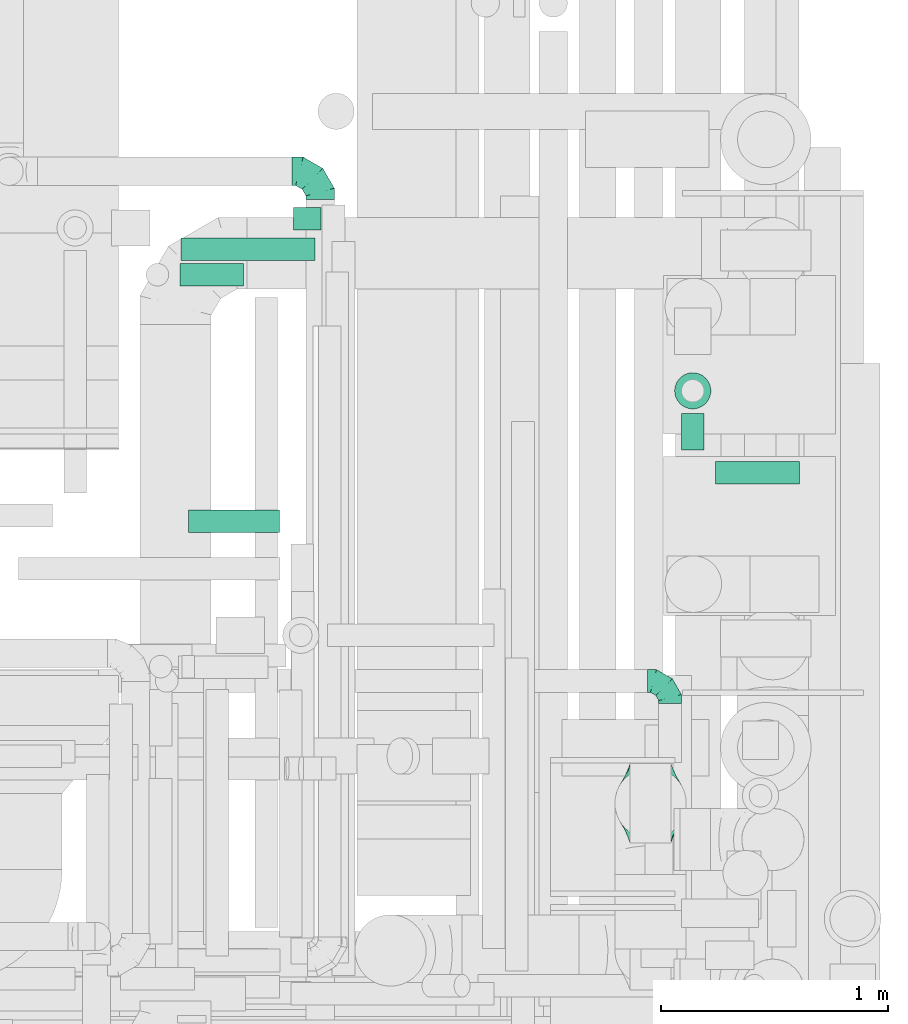
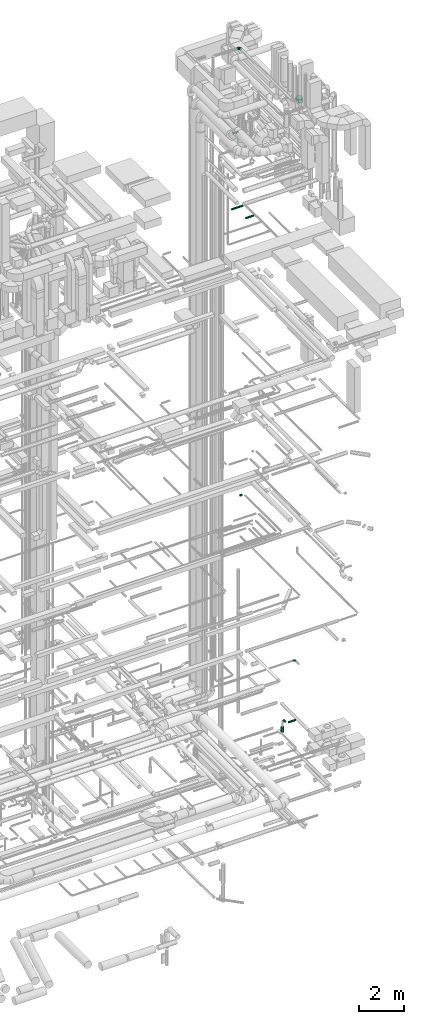
# One storey, part 309 of 337: 7 flow segments, 3 flow fittings.
"""IFC2X3 building model written with IfcOpenShell, lengths in millimetres."""

import ifcopenshell
import ifcopenshell.guid

model = None  # the IFC model being written
_history = None  # IfcOwnerHistory: only IFC2X3 demands one
_inside = {}  # id of a spatial element -> (the spatial element, [elements in it])
_under = {}  # id of a project, library or spatial element -> (it, [spatial elements below it])
_declared = {}  # id of a project -> (the project, [libraries it declares])
_typed = {}  # id of a type object -> (the type object, [elements of that type])
_made_of = {}  # id of a material, layer set ... -> (it, [elements and type objects made of it])


def new_model(schema):
    """Start an empty IFC model of exactly this schema.

    Asked for "IFC4X3", IfcOpenShell would pick the latest addendum, in which some entities
    have other attributes; the version numbers below select the first issue.
    IFC2X3 requires an IfcOwnerHistory on every rooted entity: one is made here for all.
    """
    global model, _history
    if schema == "IFC4X3":
        model = ifcopenshell.file(schema_version=(4, 3, 0, 0))
    else:
        model = ifcopenshell.file(schema=schema)
    _inside.clear()
    _under.clear()
    _declared.clear()
    _typed.clear()
    _made_of.clear()
    _history = None
    if model.schema == "IFC2X3":
        org = make("IfcOrganization", Name="unknown")
        user = make(
            "IfcPersonAndOrganization",
            ThePerson=make("IfcPerson", FamilyName="unknown"),
            TheOrganization=org,
        )
        app = make(
            "IfcApplication",
            ApplicationDeveloper=org,
            Version="unknown",
            ApplicationFullName="unknown",
            ApplicationIdentifier="unknown",
        )
        _history = make(
            "IfcOwnerHistory",
            OwningUser=user,
            OwningApplication=app,
            ChangeAction="ADDED",
            CreationDate=0,
        )
    return model


def make(cls, **values):
    """One entity of the class cls with the attributes given. An attribute that is None is left unset."""
    return model.create_entity(
        cls, **{name: value for name, value in values.items() if value is not None}
    )


def entity(cls, *values):
    """Any entity or typed value of the class cls, its attributes in the order of the schema. None: left unset."""
    e = model.create_entity(cls)
    for i, value in enumerate(values):
        if value is not None:
            e[i] = value
    return e


def rooted(cls, **values):
    """An entity with a GlobalId (a new one), such as an element, a storey or a relation."""
    return make(cls, GlobalId=ifcopenshell.guid.new(), OwnerHistory=_history, **values)


def si_unit(unit_type, name, prefix=None):
    """IfcSIUnit, for example si_unit("LENGTHUNIT", "METRE", prefix="MILLI")."""
    return make("IfcSIUnit", UnitType=unit_type, Prefix=prefix, Name=name)


def converted_unit(unit_type, name, factor, base, dimensions=None, offset=None):
    """IfcConversionBasedUnit, such as the inch: factor (a typed value) times the base unit."""
    return make(
        "IfcConversionBasedUnit"
        if offset is None
        else "IfcConversionBasedUnitWithOffset",
        ConversionOffset=offset,
        Dimensions=None
        if dimensions is None
        else entity("IfcDimensionalExponents", *dimensions),
        UnitType=unit_type,
        Name=name,
        ConversionFactor=make(
            "IfcMeasureWithUnit", ValueComponent=factor, UnitComponent=base
        ),
    )


def derived_unit(unit_type, elements):
    """IfcDerivedUnit: a product of units, each with its exponent."""
    return make(
        "IfcDerivedUnit",
        Elements=[
            make("IfcDerivedUnitElement", Unit=unit, Exponent=power)
            for unit, power in elements
        ],
        UnitType=unit_type,
    )


def assignment(units):
    """IfcUnitAssignment: the units of a project."""
    return None if units is None else make("IfcUnitAssignment", Units=units)


def point(xyz):
    """IfcCartesianPoint."""
    return None if xyz is None else make("IfcCartesianPoint", Coordinates=xyz)


def direction(xyz):
    """IfcDirection."""
    return None if xyz is None else make("IfcDirection", DirectionRatios=xyz)


def frame(location, z_axis=None, x_axis=None):
    """IfcAxis2Placement3D, a coordinate frame: its origin and axes. An axis left out is left unset."""
    return make(
        "IfcAxis2Placement3D",
        Location=point(location),
        Axis=direction(z_axis),
        RefDirection=direction(x_axis),
    )


def frame_2d(location, x_axis=None):
    """IfcAxis2Placement2D, a coordinate frame in the plane: its origin and x axis."""
    return make(
        "IfcAxis2Placement2D", Location=point(location), RefDirection=direction(x_axis)
    )


def origin():
    """The frame at (0, 0, 0) with its axes left unset."""
    return frame((0.0, 0.0, 0.0))


def origin_2d_with_axis():
    """The frame at (0, 0) in the plane with the x axis (1, 0) written out."""
    return frame_2d((0.0, 0.0), x_axis=(1.0, 0.0))


def place(relative_to, where):
    """IfcLocalPlacement: puts the frame where relative to a parent placement (None: the world)."""
    return make(
        "IfcLocalPlacement", PlacementRelTo=relative_to, RelativePlacement=where
    )


def context(
    kind, dimensions, precision=None, world=None, true_north=None, identifier=None
):
    """IfcGeometricRepresentationContext, for example the 3D "Model" context."""
    return make(
        "IfcGeometricRepresentationContext",
        ContextIdentifier=identifier,
        ContextType=kind,
        CoordinateSpaceDimension=dimensions,
        Precision=precision,
        WorldCoordinateSystem=world,
        TrueNorth=true_north,
    )


def subcontext(parent, identifier, kind, view, scale=None):
    """IfcGeometricRepresentationSubContext, for example "Body" below "Model"."""
    return make(
        "IfcGeometricRepresentationSubContext",
        ContextIdentifier=identifier,
        ContextType=kind,
        ParentContext=parent,
        TargetScale=scale,
        TargetView=view,
    )


def project(units=None, contexts=None):
    """IfcProject with its units and contexts."""
    return rooted(
        "IfcProject",
        Name="project",
        RepresentationContexts=contexts,
        UnitsInContext=assignment(units),
    )


def spatial(cls, under=None, at=None, **own):
    """A site, building, storey or space (cls), placed at a placement, below another one or the project."""
    s = rooted(cls, ObjectPlacement=at, **own)
    if under is not None:
        _under.setdefault(under.id(), (under, []))[1].append(s)
    return s


def profile(cls, at=None, kind="AREA", **sizes):
    """A parametric profile (cls). Its sizes go by their IFC names, for example OverallWidth=200.0."""
    return make(cls, ProfileType=kind, Position=at, **sizes)


def circle(**sizes):
    """IfcCircleProfileDef."""
    return profile("IfcCircleProfileDef", **sizes)


def extrude(swept, where, along, depth):
    """IfcExtrudedAreaSolid: the profile swept, set in the frame where, extruded along a direction by depth."""
    return make(
        "IfcExtrudedAreaSolid",
        SweptArea=swept,
        Position=where,
        ExtrudedDirection=direction(along),
        Depth=depth,
    )


def faces_of(points, faces, orient=None, outer=None):
    """IfcFace entities. A face is a list of loops; a loop is a list of indices into points, from 0.

    orient and outer hold one flag for each loop. By default every Orientation is true, the
    first loop of a face is its IfcFaceOuterBound and the others are IfcFaceBound.
    """
    made = []
    for i, loops in enumerate(faces):
        bounds = []
        for j, loop in enumerate(loops):
            is_outer = j == 0 if outer is None else outer[i][j]
            bounds.append(
                make(
                    "IfcFaceOuterBound" if is_outer else "IfcFaceBound",
                    Bound=make("IfcPolyLoop", Polygon=[points[k] for k in loop]),
                    Orientation=True if orient is None else orient[i][j],
                )
            )
        made.append(make("IfcFace", Bounds=bounds))
    return made


def faceted_brep(points, faces, orient=None, outer=None, voids=None):
    """IfcFacetedBrep: a solid bounded by flat faces; with voids (closed shells), ...WithVoids."""
    shared = [point(p) for p in points]
    hull = make("IfcClosedShell", CfsFaces=faces_of(shared, faces, orient, outer))
    if voids is None:
        return make("IfcFacetedBrep", Outer=hull)
    return make(
        "IfcFacetedBrepWithVoids",
        Outer=hull,
        Voids=[
            make(cls, CfsFaces=faces_of(shared, fs, o, b)) for cls, fs, o, b in voids
        ],
    )


def shape(context_of_items, identifier, shape_type, items):
    """IfcShapeRepresentation: the items that make up one representation, for example the "Body"."""
    return make(
        "IfcShapeRepresentation",
        ContextOfItems=context_of_items,
        RepresentationIdentifier=identifier,
        RepresentationType=shape_type,
        Items=items,
    )


def source(mapping_origin, context_of_items, identifier, shape_type, items):
    """IfcRepresentationMap: a shape defined once, which mapped items show again and again."""
    return make(
        "IfcRepresentationMap",
        MappingOrigin=mapping_origin,
        MappedRepresentation=shape(context_of_items, identifier, shape_type, items),
    )


def transform(
    local_origin,
    x_axis=None,
    y_axis=None,
    z_axis=None,
    scale=None,
    scale2=None,
    scale3=None,
    uniform=True,
):
    """IfcCartesianTransformationOperator3D, or its non-uniform kind. x_axis, y_axis, z_axis: its Axis1, 2, 3."""
    if uniform:
        return make(
            "IfcCartesianTransformationOperator3D",
            Axis1=direction(x_axis),
            Axis2=direction(y_axis),
            LocalOrigin=point(local_origin),
            Scale=scale,
            Axis3=direction(z_axis),
        )
    return make(
        "IfcCartesianTransformationOperator3DnonUniform",
        Axis1=direction(x_axis),
        Axis2=direction(y_axis),
        LocalOrigin=point(local_origin),
        Scale=scale,
        Axis3=direction(z_axis),
        Scale2=scale2,
        Scale3=scale3,
    )


def mapped(mapping_source, mapping_target):
    """IfcMappedItem: shows the shape of a source again, moved by a transform."""
    return make(
        "IfcMappedItem", MappingSource=mapping_source, MappingTarget=mapping_target
    )


def material(Name=None, Category=None):
    """IfcMaterial."""
    return make("IfcMaterial", Name=Name, Category=Category)


def made_of(thing, what):
    """Note that an element or type object is made of a material, layer set ...; save() writes the relation."""
    if what is not None:
        _made_of.setdefault(what.id(), (what, []))[1].append(thing)
    return thing


def type_object(cls, material=None, **own):
    """A type object (cls), such as IfcWallType, which elements share."""
    return made_of(rooted(cls, **own), material)


def type_shapes(of_type, sources):
    """Give a type object the sources (RepresentationMaps) that its elements show as mapped items."""
    of_type.RepresentationMaps = sources


def element(
    cls,
    number,
    at=None,
    inside=None,
    cuts=None,
    type_object=None,
    material=None,
    context=None,
    identifier="Body",
    shape_type=None,
    held_by="IfcProductDefinitionShape",
    body=None,
    shapes=None,
    **own,
):
    """One element of the class cls, such as IfcWall. Its Tag is "e" and its number.

    at: its placement. inside: the storey or other place that contains it. cuts: it is an
    opening in that element (IfcRelVoidsElement). A single representation is given by context,
    identifier, shape_type and body (its items); several are given by shapes. held_by: the class
    of the entity that holds the representations. save() writes the other relations.
    """
    e = rooted(cls, Tag="e%d" % number, ObjectPlacement=at, **own)
    if body is not None:
        shapes = [shape(context, identifier, shape_type, body)]
    if shapes is not None:
        e.Representation = make(held_by, Representations=shapes)
    if inside is not None:
        _inside.setdefault(inside.id(), (inside, []))[1].append(e)
    if cuts is not None:
        rooted(
            "IfcRelVoidsElement", RelatingBuildingElement=cuts, RelatedOpeningElement=e
        )
    if type_object is not None:
        _typed.setdefault(type_object.id(), (type_object, []))[1].append(e)
    return made_of(e, material)


def aggregate(whole, parts):
    """IfcRelAggregates: a whole, such as a stair, and the parts it consists of."""
    return rooted("IfcRelAggregates", RelatingObject=whole, RelatedObjects=parts)


def save(model, path):
    """Write the relations noted so far, then the file.

    IfcRelAggregates (storeys below a building ...), IfcRelContainedInSpatialStructure (elements
    in a storey), IfcRelDefinesByType, IfcRelAssociatesMaterial and IfcRelDeclares: one each for
    every whole, place, type object, material and project.
    """
    for whole, parts in _under.values():
        aggregate(whole, parts)
    for where, things in _inside.values():
        rooted(
            "IfcRelContainedInSpatialStructure",
            RelatedElements=things,
            RelatingStructure=where,
        )
    for kind, things in _typed.values():
        rooted("IfcRelDefinesByType", RelatedObjects=things, RelatingType=kind)
    for what, things in _made_of.values():
        rooted("IfcRelAssociatesMaterial", RelatedObjects=things, RelatingMaterial=what)
    for by, libraries in _declared.values():
        rooted("IfcRelDeclares", RelatingContext=by, RelatedDefinitions=libraries)
    model.write(path)


model = new_model("IFC2X3")

# Units and contexts
model_context = context("Model", 3, precision=0.01, world=origin(), true_north=direction((6.12303176911189e-17, 1.0)))
body_context = subcontext(model_context, "Body", "Model", "MODEL_VIEW")
ifc_project = project(units=[si_unit("LENGTHUNIT", "METRE", prefix="MILLI"), si_unit("AREAUNIT", "SQUARE_METRE"), si_unit("VOLUMEUNIT", "CUBIC_METRE"), converted_unit("PLANEANGLEUNIT", "DEGREE", entity("IfcRatioMeasure", 0.0174532925199433), si_unit("PLANEANGLEUNIT", "RADIAN"), dimensions=[0, 0, 0, 0, 0, 0, 0]), si_unit("MASSUNIT", "GRAM", prefix="KILO"), derived_unit("MASSDENSITYUNIT", [(si_unit("MASSUNIT", "GRAM", prefix="KILO"), 1), (si_unit("LENGTHUNIT", "METRE"), -3)]), derived_unit("MOMENTOFINERTIAUNIT", [(si_unit("LENGTHUNIT", "METRE"), 4)]), si_unit("TIMEUNIT", "SECOND"), si_unit("FREQUENCYUNIT", "HERTZ"), si_unit("THERMODYNAMICTEMPERATUREUNIT", "DEGREE_CELSIUS"), derived_unit("THERMALTRANSMITTANCEUNIT", [(si_unit("MASSUNIT", "GRAM", prefix="KILO"), 1), (si_unit("THERMODYNAMICTEMPERATUREUNIT", "KELVIN"), -1), (si_unit("TIMEUNIT", "SECOND"), -3)]), derived_unit("VOLUMETRICFLOWRATEUNIT", [(si_unit("LENGTHUNIT", "METRE"), 3), (si_unit("TIMEUNIT", "SECOND"), -1)]), derived_unit("MASSFLOWRATEUNIT", [(si_unit("MASSUNIT", "GRAM", prefix="KILO"), 1), (si_unit("TIMEUNIT", "SECOND"), -1)]), derived_unit("ROTATIONALFREQUENCYUNIT", [(si_unit("TIMEUNIT", "SECOND"), -1)]), si_unit("ELECTRICCURRENTUNIT", "AMPERE"), si_unit("ELECTRICVOLTAGEUNIT", "VOLT"), si_unit("POWERUNIT", "WATT"), si_unit("FORCEUNIT", "NEWTON", prefix="KILO"), si_unit("ILLUMINANCEUNIT", "LUX"), si_unit("LUMINOUSFLUXUNIT", "LUMEN"), si_unit("LUMINOUSINTENSITYUNIT", "CANDELA"), derived_unit("USERDEFINED", [(si_unit("MASSUNIT", "GRAM", prefix="KILO"), -1), (si_unit("LENGTHUNIT", "METRE"), -2), (si_unit("TIMEUNIT", "SECOND"), 3), (si_unit("LUMINOUSFLUXUNIT", "LUMEN"), 1)]), derived_unit("LINEARVELOCITYUNIT", [(si_unit("LENGTHUNIT", "METRE"), 1), (si_unit("TIMEUNIT", "SECOND"), -1)]), si_unit("PRESSUREUNIT", "PASCAL"), derived_unit("USERDEFINED", [(si_unit("LENGTHUNIT", "METRE"), -2), (si_unit("MASSUNIT", "GRAM", prefix="KILO"), 1), (si_unit("TIMEUNIT", "SECOND"), -2)]), derived_unit("LINEARFORCEUNIT", [(si_unit("MASSUNIT", "GRAM", prefix="KILO"), 1), (si_unit("LENGTHUNIT", "METRE"), 1), (si_unit("TIMEUNIT", "SECOND"), -2), (si_unit("LENGTHUNIT", "METRE"), -1)]), derived_unit("PLANARFORCEUNIT", [(si_unit("MASSUNIT", "GRAM", prefix="KILO"), 1), (si_unit("LENGTHUNIT", "METRE"), 1), (si_unit("TIMEUNIT", "SECOND"), -2), (si_unit("LENGTHUNIT", "METRE"), -2)])], contexts=[model_context])

# Site, building, storey
site_placement = place(None, origin())
site = spatial("IfcSite", under=ifc_project, at=site_placement, CompositionType="ELEMENT")
building_placement = place(site_placement, origin())
building = spatial("IfcBuilding", under=site, at=building_placement, CompositionType="ELEMENT")
storey_placement = place(building_placement, origin())
storey = spatial("IfcBuildingStorey", under=building, at=storey_placement, CompositionType="ELEMENT", Elevation=0.0)

# Flow segments
duct_segment_type = type_object("IfcDuctSegmentType", PredefinedType="NOTDEFINED")
flow_segment_1_placement = place(storey_placement, frame((72489.32, 12422.94, -851.6)))
element("IfcFlowSegment", 1, at=flow_segment_1_placement, inside=storey, type_object=duct_segment_type, context=body_context, shape_type="SweptSolid", body=[
    extrude(circle(Radius=50.0, at=origin_2d_with_axis()), frame((0.0, 51.6, 51.6), z_axis=(1.0, 0.0, 0.0), x_axis=(0.0, 1.0, 0.0)), (0.0, 0.0, 1.0), 371.932269999986),
])
flow_segment_2_placement = place(storey_placement, frame((72337.72, 12574.53, -851.6)))
element("IfcFlowSegment", 2, at=flow_segment_2_placement, inside=storey, type_object=duct_segment_type, context=body_context, shape_type="SweptSolid", body=[
    extrude(circle(Radius=50.0, at=origin_2d_with_axis()), frame((51.6, 0.0, 51.6), z_axis=(0.0, 1.0, 0.0), x_axis=(1.0, 0.0, 0.0)), (0.0, 0.0, 1.0), 161.46705),
])
flow_segment_3_placement = place(storey_placement, frame((72307.72, 12754.4, -1493.0)))
element("IfcFlowSegment", 3, at=flow_segment_3_placement, inside=storey, type_object=duct_segment_type, context=body_context, shape_type="SweptSolid", body=[
    extrude(circle(Radius=80.0, at=origin_2d_with_axis()), frame((81.6, 81.6, 0.0), z_axis=(0.0, 0.0, 1.0), x_axis=(-1.0, 0.0, 0.0)), (0.0, 0.0, 1.0), 267.000000000001),
])
flow_segment_4_placement = place(storey_placement, frame((70627.71, 13544.0, 11468.4)))
element("IfcFlowSegment", 4, at=flow_segment_4_placement, inside=storey, type_object=duct_segment_type, context=body_context, shape_type="SweptSolid", body=[
    extrude(circle(Radius=50.0, at=origin_2d_with_axis()), frame((0.0, 51.6, 51.6), z_axis=(1.0, 0.0, 0.0), x_axis=(0.0, 1.0, 0.0)), (0.0, 0.0, 1.0), 119.999999999999),
])
flow_segment_5_placement = place(storey_placement, frame((70130.86, 13409.66, 27308.4)))
element("IfcFlowSegment", 5, at=flow_segment_5_placement, inside=storey, type_object=duct_segment_type, context=body_context, shape_type="SweptSolid", body=[
    extrude(circle(Radius=50.0, at=origin_2d_with_axis()), frame((0.0, 51.6, 51.6), z_axis=(1.0, 0.0, 0.0), x_axis=(0.0, 1.0, 0.0)), (0.0, 0.0, 1.0), 589.999999999979),
])
flow_segment_6_placement = place(storey_placement, frame((70163.63, 12208.48, 27548.4)))
element("IfcFlowSegment", 6, at=flow_segment_6_placement, inside=storey, type_object=duct_segment_type, context=body_context, shape_type="SweptSolid", body=[
    extrude(circle(Radius=50.0, at=origin_2d_with_axis()), frame((0.0, 51.6, 51.6), z_axis=(1.0, 0.0, 0.0), x_axis=(0.0, 1.0, 0.0)), (0.0, 0.0, 1.0), 401.25),
])
flow_segment_7_placement = place(storey_placement, frame((70126.3, 13296.82, 31518.4)))
element("IfcFlowSegment", 7, at=flow_segment_7_placement, inside=storey, type_object=duct_segment_type, context=body_context, shape_type="SweptSolid", body=[
    extrude(circle(Radius=50.0, at=origin_2d_with_axis()), frame((0.0, 51.6, 51.6), z_axis=(1.0, 0.0, 0.0), x_axis=(0.0, 1.0, 0.0)), (0.0, 0.0, 1.0), 280.000000000014),
])

# Flow fittings
ifc_material = material()
duct_fitting_type_1 = type_object("IfcDuctFittingType", PredefinedType="NOTDEFINED", material=ifc_material)
shared_shape_1 = source(origin(), body_context, "Body", "Brep", [
    faceted_brep([(-100.0, 0.0, -50.0), (-100.0, -12.94, -48.3), (-100.0, -25.0, -43.3), (-100.0, -35.36, -35.36), (-100.0, -43.3, -25.0), (-100.0, -48.3, -12.94), (-100.0, -50.0, 0.0), (-100.0, -48.3, 12.94), (-100.0, -43.3, 25.0), (-100.0, -35.36, 35.36), (-100.0, -25.0, 43.3), (-100.0, -12.94, 48.3), (-100.0, 0.0, 50.0), (-100.0, 12.94, 48.3), (-100.0, 25.0, 43.3), (-100.0, 35.36, 35.36), (-100.0, 43.3, 25.0), (-100.0, 48.3, 12.94), (-100.0, 50.0, 0.0), (-100.0, 48.3, -12.94), (-100.0, 43.3, -25.0), (-100.0, 35.36, -35.36), (-100.0, 25.0, -43.3), (-100.0, 12.94, -48.3), (-76.67, 12.94, 48.3), (-79.9, 25.0, 43.3), (-73.21, 0.0, 50.0), (-82.68, 35.36, 35.36), (-86.15, 48.3, 12.94), (-86.6, 50.0, 0.0), (-84.81, 43.3, 25.0), (-84.81, 43.3, -25.0), (-82.68, 35.36, -35.36), (-86.15, 48.3, -12.94), (-76.67, 12.94, -48.3), (-73.21, 0.0, -50.0), (-79.9, 25.0, -43.3), (-69.74, -12.94, -48.3), (-66.51, -25.0, -43.3), (-63.73, -35.36, -35.36), (-61.6, -43.3, -25.0), (-60.26, -48.3, -12.94), (-59.81, -50.0, 0.0), (-60.26, -48.3, 12.94), (-61.6, -43.3, 25.0), (-63.73, -35.36, 35.36), (-66.51, -25.0, 43.3), (-69.74, -12.94, 48.3), (-36.27, 36.27, 48.3), (-45.1, 45.1, 43.3), (-26.79, 26.79, 50.0), (-52.68, 52.68, 35.36), (-58.49, 58.49, 25.0), (-62.15, 62.15, 12.94), (-63.4, 63.4, 0.0), (-62.15, 62.15, -12.94), (-58.49, 58.49, -25.0), (-52.68, 52.68, -35.36), (-36.27, 36.27, -48.3), (-26.79, 26.79, -50.0), (-45.1, 45.1, -43.3), (-17.32, 17.32, -48.3), (-8.49, 8.49, -43.3), (-0.91, 0.91, -35.36), (4.9, -4.9, -25.0), (8.56, -8.56, -12.94), (9.81, -9.81, 0.0), (8.56, -8.56, 12.94), (4.9, -4.9, 25.0), (-0.91, 0.91, 35.36), (-8.49, 8.49, 43.3), (-17.32, 17.32, 48.3), (-12.94, 76.67, 48.3), (-25.0, 79.9, 43.3), (0.0, 73.21, 50.0), (-35.36, 82.68, 35.36), (-43.3, 84.81, 25.0), (-48.3, 86.15, 12.94), (-50.0, 86.6, 0.0), (-48.3, 86.15, -12.94), (-43.3, 84.81, -25.0), (-35.36, 82.68, -35.36), (-12.94, 76.67, -48.3), (0.0, 73.21, -50.0), (-25.0, 79.9, -43.3), (12.94, 69.74, -48.3), (25.0, 66.51, -43.3), (35.36, 63.73, -35.36), (43.3, 61.6, -25.0), (48.3, 60.26, -12.94), (50.0, 59.81, 0.0), (48.3, 60.26, 12.94), (43.3, 61.6, 25.0), (35.36, 63.73, 35.36), (25.0, 66.51, 43.3), (12.94, 69.74, 48.3), (-12.94, 100.0, -48.3), (-25.0, 100.0, -43.3), (-35.36, 100.0, -35.36), (-43.3, 100.0, -25.0), (-48.3, 100.0, -12.94), (-50.0, 100.0, 0.0), (-48.3, 100.0, 12.94), (-43.3, 100.0, 25.0), (-35.36, 100.0, 35.36), (-25.0, 100.0, 43.3), (-12.94, 100.0, 48.3), (0.0, 100.0, 50.0), (12.94, 100.0, 48.3), (25.0, 100.0, 43.3), (35.36, 100.0, 35.36), (43.3, 100.0, 25.0), (48.3, 100.0, 12.94), (50.0, 100.0, 0.0), (48.3, 100.0, -12.94), (43.3, 100.0, -25.0), (35.36, 100.0, -35.36), (25.0, 100.0, -43.3), (12.94, 100.0, -48.3), (0.0, 100.0, -50.0)], [[[0, 1, 2, 3, 4, 5, 6, 7, 8, 9, 10, 11, 12, 13, 14, 15, 16, 17, 18, 19, 20, 21, 22, 23]], [[24, 25, 14, 13]], [[26, 24, 13, 12]], [[14, 25, 27, 15]], [[28, 29, 18, 17]], [[30, 28, 17, 16]], [[15, 27, 30, 16]], [[20, 31, 32, 21]], [[33, 31, 20, 19]], [[18, 29, 33, 19]], [[34, 35, 0, 23]], [[36, 34, 23, 22]], [[32, 36, 22, 21]], [[2, 1, 37, 38]], [[3, 2, 38, 39]], [[0, 35, 37, 1]], [[5, 4, 40, 41]], [[6, 5, 41, 42]], [[3, 39, 40, 4]], [[6, 42, 43, 7]], [[7, 43, 44, 8]], [[8, 44, 45, 9]], [[10, 46, 47, 11]], [[11, 47, 26, 12]], [[10, 9, 45, 46]], [[48, 49, 25, 24]], [[50, 48, 24, 26]], [[27, 25, 49, 51]], [[52, 53, 28, 30]], [[51, 52, 30, 27]], [[29, 28, 53, 54]], [[55, 56, 31, 33]], [[54, 55, 33, 29]], [[57, 32, 31, 56]], [[58, 59, 35, 34]], [[60, 58, 34, 36]], [[57, 60, 36, 32]], [[37, 35, 59, 61]], [[38, 37, 61, 62]], [[39, 38, 62, 63]], [[41, 40, 64, 65]], [[42, 41, 65, 66]], [[63, 64, 40, 39]], [[43, 42, 66, 67]], [[44, 43, 67, 68]], [[68, 69, 45, 44]], [[46, 45, 69, 70]], [[47, 46, 70, 71]], [[26, 47, 71, 50]], [[72, 73, 49, 48]], [[74, 72, 48, 50]], [[51, 49, 73, 75]], [[76, 77, 53, 52]], [[75, 76, 52, 51]], [[54, 53, 77, 78]], [[79, 80, 56, 55]], [[78, 79, 55, 54]], [[81, 57, 56, 80]], [[82, 83, 59, 58]], [[84, 82, 58, 60]], [[81, 84, 60, 57]], [[61, 59, 83, 85]], [[62, 61, 85, 86]], [[63, 62, 86, 87]], [[65, 64, 88, 89]], [[66, 65, 89, 90]], [[87, 88, 64, 63]], [[67, 66, 90, 91]], [[68, 67, 91, 92]], [[92, 93, 69, 68]], [[70, 69, 93, 94]], [[71, 70, 94, 95]], [[50, 71, 95, 74]], [[96, 97, 98, 99, 100, 101, 102, 103, 104, 105, 106, 107, 108, 109, 110, 111, 112, 113, 114, 115, 116, 117, 118, 119]], [[72, 74, 107, 106]], [[73, 72, 106, 105]], [[75, 73, 105, 104]], [[77, 76, 103, 102]], [[78, 77, 102, 101]], [[75, 104, 103, 76]], [[78, 101, 100, 79]], [[79, 100, 99, 80]], [[80, 99, 98, 81]], [[96, 119, 83, 82]], [[97, 96, 82, 84]], [[84, 81, 98, 97]], [[83, 119, 118, 85]], [[85, 118, 117, 86]], [[86, 117, 116, 87]], [[88, 115, 114, 89]], [[89, 114, 113, 90]], [[87, 116, 115, 88]], [[91, 90, 113, 112]], [[92, 91, 112, 111]], [[93, 92, 111, 110]], [[95, 94, 109, 108]], [[74, 95, 108, 107]], [[110, 109, 94, 93]]]),
])
type_shapes(duct_fitting_type_1, [shared_shape_1])
flow_fitting_1_placement = place(storey_placement, frame((72289.2, 11555.25, 3220.0), z_axis=(0.0, 0.0, 1.0), x_axis=(0.0, 1.0, 0.0)))
element("IfcFlowFitting", 8, at=flow_fitting_1_placement, inside=storey, type_object=duct_fitting_type_1, material=ifc_material, context=body_context, shape_type="MappedRepresentation", body=[
    mapped(shared_shape_1, transform((0.0, 0.0, 0.0), scale=1.0)),
])
duct_fitting_type_2 = type_object("IfcDuctFittingType", PredefinedType="NOTDEFINED", material=ifc_material)
shared_shape_2 = source(origin(), body_context, "Body", "Brep", [
    faceted_brep([(-125.0, 0.0, -62.5), (-125.0, -16.18, -60.37), (-125.0, -31.25, -54.13), (-125.0, -44.19, -44.19), (-125.0, -54.13, -31.25), (-125.0, -60.37, -16.18), (-125.0, -62.5, 0.0), (-125.0, -60.37, 16.18), (-125.0, -54.13, 31.25), (-125.0, -44.19, 44.19), (-125.0, -31.25, 54.13), (-125.0, -16.18, 60.37), (-125.0, 0.0, 62.5), (-125.0, 16.18, 60.37), (-125.0, 31.25, 54.13), (-125.0, 44.19, 44.19), (-125.0, 54.13, 31.25), (-125.0, 60.37, 16.18), (-125.0, 62.5, 0.0), (-125.0, 60.37, -16.18), (-125.0, 54.13, -31.25), (-125.0, 44.19, -44.19), (-125.0, 31.25, -54.13), (-125.0, 16.18, -60.37), (-95.84, 16.18, 60.37), (-99.88, 31.25, 54.13), (-91.51, 0.0, 62.5), (-103.35, 44.19, 44.19), (-107.68, 60.37, 16.18), (-108.25, 62.5, 0.0), (-106.01, 54.13, 31.25), (-106.01, 54.13, -31.25), (-103.35, 44.19, -44.19), (-107.68, 60.37, -16.18), (-95.84, 16.18, -60.37), (-91.51, 0.0, -62.5), (-99.88, 31.25, -54.13), (-87.17, -16.18, -60.37), (-83.13, -31.25, -54.13), (-79.66, -44.19, -44.19), (-77.0, -54.13, -31.25), (-75.33, -60.37, -16.18), (-74.76, -62.5, 0.0), (-75.33, -60.37, 16.18), (-77.0, -54.13, 31.25), (-79.66, -44.19, 44.19), (-83.13, -31.25, 54.13), (-87.17, -16.18, 60.37), (-45.34, 45.34, 60.37), (-56.37, 56.37, 54.13), (-33.49, 33.49, 62.5), (-65.85, 65.85, 44.19), (-73.12, 73.12, 31.25), (-77.69, 77.69, 16.18), (-79.25, 79.25, 0.0), (-77.69, 77.69, -16.18), (-73.12, 73.12, -31.25), (-65.85, 65.85, -44.19), (-45.34, 45.34, -60.37), (-33.49, 33.49, -62.5), (-56.37, 56.37, -54.13), (-21.65, 21.65, -60.37), (-10.62, 10.62, -54.13), (-1.14, 1.14, -44.19), (6.13, -6.13, -31.25), (10.7, -10.7, -16.18), (12.26, -12.26, 0.0), (10.7, -10.7, 16.18), (6.13, -6.13, 31.25), (-1.14, 1.14, 44.19), (-10.62, 10.62, 54.13), (-21.65, 21.65, 60.37), (-16.18, 95.84, 60.37), (-31.25, 99.88, 54.13), (0.0, 91.51, 62.5), (-44.19, 103.35, 44.19), (-54.13, 106.01, 31.25), (-60.37, 107.68, 16.18), (-62.5, 108.25, 0.0), (-60.37, 107.68, -16.18), (-54.13, 106.01, -31.25), (-44.19, 103.35, -44.19), (-16.18, 95.84, -60.37), (0.0, 91.51, -62.5), (-31.25, 99.88, -54.13), (16.18, 87.17, -60.37), (31.25, 83.13, -54.13), (44.19, 79.66, -44.19), (54.13, 77.0, -31.25), (60.37, 75.33, -16.18), (62.5, 74.76, 0.0), (60.37, 75.33, 16.18), (54.13, 77.0, 31.25), (44.19, 79.66, 44.19), (31.25, 83.13, 54.13), (16.18, 87.17, 60.37), (-16.18, 125.0, -60.37), (-31.25, 125.0, -54.13), (-44.19, 125.0, -44.19), (-54.13, 125.0, -31.25), (-60.37, 125.0, -16.18), (-62.5, 125.0, 0.0), (-60.37, 125.0, 16.18), (-54.13, 125.0, 31.25), (-44.19, 125.0, 44.19), (-31.25, 125.0, 54.13), (-16.18, 125.0, 60.37), (0.0, 125.0, 62.5), (16.18, 125.0, 60.37), (31.25, 125.0, 54.13), (44.19, 125.0, 44.19), (54.13, 125.0, 31.25), (60.37, 125.0, 16.18), (62.5, 125.0, 0.0), (60.37, 125.0, -16.18), (54.13, 125.0, -31.25), (44.19, 125.0, -44.19), (31.25, 125.0, -54.13), (16.18, 125.0, -60.37), (0.0, 125.0, -62.5)], [[[0, 1, 2, 3, 4, 5, 6, 7, 8, 9, 10, 11, 12, 13, 14, 15, 16, 17, 18, 19, 20, 21, 22, 23]], [[24, 25, 14, 13]], [[26, 24, 13, 12]], [[14, 25, 27, 15]], [[28, 29, 18, 17]], [[30, 28, 17, 16]], [[15, 27, 30, 16]], [[20, 31, 32, 21]], [[33, 31, 20, 19]], [[18, 29, 33, 19]], [[34, 35, 0, 23]], [[36, 34, 23, 22]], [[21, 32, 36, 22]], [[1, 0, 35, 37]], [[2, 1, 37, 38]], [[38, 39, 3, 2]], [[5, 4, 40, 41]], [[6, 5, 41, 42]], [[39, 40, 4, 3]], [[6, 42, 43, 7]], [[7, 43, 44, 8]], [[45, 9, 8, 44]], [[9, 45, 46, 10]], [[10, 46, 47, 11]], [[26, 12, 11, 47]], [[48, 49, 25, 24]], [[50, 48, 24, 26]], [[27, 25, 49, 51]], [[52, 53, 28, 30]], [[51, 52, 30, 27]], [[29, 28, 53, 54]], [[55, 56, 31, 33]], [[54, 55, 33, 29]], [[57, 32, 31, 56]], [[58, 59, 35, 34]], [[60, 58, 34, 36]], [[57, 60, 36, 32]], [[37, 35, 59, 61]], [[38, 37, 61, 62]], [[39, 38, 62, 63]], [[41, 40, 64, 65]], [[42, 41, 65, 66]], [[63, 64, 40, 39]], [[43, 42, 66, 67]], [[44, 43, 67, 68]], [[68, 69, 45, 44]], [[46, 45, 69, 70]], [[47, 46, 70, 71]], [[26, 47, 71, 50]], [[72, 73, 49, 48]], [[74, 72, 48, 50]], [[51, 49, 73, 75]], [[76, 77, 53, 52]], [[75, 76, 52, 51]], [[54, 53, 77, 78]], [[79, 80, 56, 55]], [[78, 79, 55, 54]], [[81, 57, 56, 80]], [[82, 83, 59, 58]], [[84, 82, 58, 60]], [[81, 84, 60, 57]], [[61, 59, 83, 85]], [[62, 61, 85, 86]], [[63, 62, 86, 87]], [[65, 64, 88, 89]], [[66, 65, 89, 90]], [[87, 88, 64, 63]], [[67, 66, 90, 91]], [[68, 67, 91, 92]], [[92, 93, 69, 68]], [[70, 69, 93, 94]], [[71, 70, 94, 95]], [[50, 71, 95, 74]], [[96, 97, 98, 99, 100, 101, 102, 103, 104, 105, 106, 107, 108, 109, 110, 111, 112, 113, 114, 115, 116, 117, 118, 119]], [[72, 74, 107, 106]], [[73, 72, 106, 105]], [[75, 73, 105, 104]], [[77, 76, 103, 102]], [[78, 77, 102, 101]], [[75, 104, 103, 76]], [[78, 101, 100, 79]], [[79, 100, 99, 80]], [[80, 99, 98, 81]], [[96, 119, 83, 82]], [[97, 96, 82, 84]], [[84, 81, 98, 97]], [[83, 119, 118, 85]], [[85, 118, 117, 86]], [[116, 87, 86, 117]], [[88, 115, 114, 89]], [[89, 114, 113, 90]], [[115, 88, 87, 116]], [[91, 90, 113, 112]], [[92, 91, 112, 111]], [[111, 110, 93, 92]], [[95, 94, 109, 108]], [[74, 95, 108, 107]], [[110, 109, 94, 93]]]),
])
type_shapes(duct_fitting_type_2, [shared_shape_2])
flow_fitting_2_placement = place(storey_placement, frame((70744.58, 13805.0, 35740.0), z_axis=(0.0, 0.0, 1.0), x_axis=(0.0, 1.0, 0.0)))
element("IfcFlowFitting", 9, at=flow_fitting_2_placement, inside=storey, type_object=duct_fitting_type_2, material=ifc_material, context=body_context, shape_type="MappedRepresentation", body=[
    mapped(shared_shape_2, transform((0.0, 0.0, 0.0), scale=1.0)),
])
duct_fitting_type_3 = type_object("IfcDuctFittingType", PredefinedType="NOTDEFINED", material=ifc_material)
shared_shape_3 = source(origin(), body_context, "Body", "Brep", [
    faceted_brep([(200.0, 78.75, 136.4), (200.0, 59.76, 144.27), (200.0, 40.76, 152.13), (200.0, 27.93, 153.82), (200.0, 15.1, 155.51), (200.0, 0.0, 157.5), (200.0, -15.1, 155.51), (200.0, -27.93, 153.82), (200.0, -40.76, 152.13), (200.0, -59.76, 144.27), (200.0, -78.75, 136.4), (200.0, -95.06, 123.88), (200.0, -111.37, 111.37), (200.0, -123.88, 95.06), (200.0, -136.4, 78.75), (200.0, -144.27, 59.76), (200.0, -152.13, 40.76), (200.0, -153.82, 27.93), (200.0, -155.51, 15.1), (200.0, -157.5, 0.0), (200.0, -155.51, -15.1), (200.0, -153.82, -27.93), (200.0, -152.13, -40.76), (200.0, -144.27, -59.76), (200.0, -136.4, -78.75), (200.0, -123.88, -95.06), (200.0, -111.37, -111.37), (200.0, -95.06, -123.88), (200.0, -78.75, -136.4), (200.0, -59.76, -144.27), (200.0, -40.76, -152.13), (200.0, -27.93, -153.82), (200.0, -15.1, -155.51), (200.0, 0.0, -157.5), (200.0, 15.1, -155.51), (200.0, 27.93, -153.82), (200.0, 40.76, -152.13), (200.0, 59.76, -144.27), (200.0, 78.75, -136.4), (200.0, 95.06, -123.88), (200.0, 111.37, -111.37), (200.0, 123.88, -95.06), (200.0, 136.4, -78.75), (200.0, 144.27, -59.76), (200.0, 152.13, -40.76), (200.0, 153.82, -27.93), (200.0, 155.51, -15.1), (200.0, 157.5, 0.0), (200.0, 155.51, 15.1), (200.0, 153.82, 27.93), (200.0, 152.13, 40.76), (200.0, 144.27, 59.76), (200.0, 136.4, 78.75), (200.0, 123.88, 95.06), (200.0, 111.37, 111.37), (200.0, 95.06, 123.88), (0.0, -90.0, 175.0), (0.0, 90.0, 175.0), (0.0, 90.0, -175.0), (0.0, -90.0, -175.0), (128.09, -32.36, 163.79), (104.11, -43.15, 165.89), (78.09, -54.86, 168.17), (100.0, -97.21, 146.45), (26.03, -78.29, 172.72), (52.06, -107.57, 129.45), (26.03, -98.78, 152.23), (78.09, -116.35, 106.68), (104.11, -125.14, 83.9), (128.09, -133.23, 62.93), (176.03, -10.79, 159.6), (152.06, -21.57, 161.7), (152.06, -141.32, 41.95), (176.03, -149.41, 20.98), (52.06, -66.57, 170.45), (26.03, -98.78, -152.23), (52.06, -107.57, -129.45), (78.09, -116.35, -106.68), (104.11, -125.14, -83.9), (128.09, -133.23, -62.93), (152.06, -141.32, -41.95), (176.03, -149.41, -20.98), (100.0, -103.95, -139.71), (52.06, -66.57, -170.45), (26.03, -78.29, -172.72), (78.09, -54.86, -168.17), (104.11, -43.15, -165.89), (128.09, -32.36, -163.79), (152.06, -21.57, -161.7), (176.03, -10.79, -159.6), (26.03, 78.29, -172.72), (52.06, 66.57, -170.45), (78.09, 54.86, -168.17), (104.11, 43.15, -165.89), (128.09, 32.36, -163.79), (152.06, 21.57, -161.7), (176.03, 10.79, -159.6), (100.0, 97.21, -146.45), (52.06, 107.57, -129.45), (26.03, 98.78, -152.23), (78.09, 116.35, -106.68), (104.11, 125.14, -83.9), (128.09, 133.23, -62.93), (152.06, 141.32, -41.95), (176.03, 149.41, -20.98), (26.03, 98.78, 152.23), (52.06, 107.57, 129.45), (78.09, 116.35, 106.68), (104.11, 125.14, 83.9), (128.09, 133.23, 62.93), (152.06, 141.32, 41.95), (176.03, 149.41, 20.98), (100.0, 103.95, 139.71), (52.06, 66.57, 170.45), (26.03, 78.29, 172.72), (78.09, 54.86, 168.17), (104.11, 43.15, 165.89), (128.09, 32.36, 163.79), (152.06, 21.57, 161.7), (176.03, 10.79, 159.6)], [[[0, 1, 2, 3, 4, 5, 6, 7, 8, 9, 10, 11, 12, 13, 14, 15, 16, 17, 18, 19, 20, 21, 22, 23, 24, 25, 26, 27, 28, 29, 30, 31, 32, 33, 34, 35, 36, 37, 38, 39, 40, 41, 42, 43, 44, 45, 46, 47, 48, 49, 50, 51, 52, 53, 54, 55]], [[56, 57, 58, 59]], [[60, 61, 62, 9]], [[63, 11, 64]], [[13, 12, 63]], [[8, 60, 9]], [[9, 62, 10]], [[65, 14, 13]], [[13, 63, 66]], [[15, 67, 68, 69]], [[70, 71, 60, 8, 7, 6, 5]], [[17, 16, 69, 72, 73, 19, 18]], [[15, 14, 67]], [[15, 69, 16]], [[14, 65, 67]], [[11, 74, 64]], [[11, 10, 74]], [[56, 63, 64]], [[11, 63, 12]], [[13, 66, 65]], [[63, 56, 66]], [[62, 74, 10]], [[73, 72, 69, 68, 67, 65, 66, 56, 59, 75, 76, 77, 78, 79, 80, 81, 19]], [[79, 78, 77, 23]], [[82, 25, 75]], [[27, 26, 82]], [[22, 79, 23]], [[23, 77, 24]], [[83, 28, 27]], [[27, 82, 84]], [[29, 85, 86, 87]], [[81, 80, 79, 22, 21, 20, 19]], [[31, 30, 87, 88, 89, 33, 32]], [[29, 28, 85]], [[29, 87, 30]], [[28, 83, 85]], [[25, 76, 75]], [[25, 24, 76]], [[59, 82, 75]], [[25, 82, 26]], [[27, 84, 83]], [[82, 59, 84]], [[77, 76, 24]], [[89, 88, 87, 86, 85, 83, 84, 59, 58, 90, 91, 92, 93, 94, 95, 96, 33]], [[94, 93, 92, 37]], [[97, 39, 90]], [[41, 40, 97]], [[36, 94, 37]], [[37, 92, 38]], [[98, 42, 41]], [[41, 97, 99]], [[43, 100, 101, 102]], [[96, 95, 94, 36, 35, 34, 33]], [[45, 44, 102, 103, 104, 47, 46]], [[43, 42, 100]], [[43, 102, 44]], [[42, 98, 100]], [[39, 91, 90]], [[39, 38, 91]], [[58, 97, 90]], [[39, 97, 40]], [[41, 99, 98]], [[97, 58, 99]], [[92, 91, 38]], [[58, 57, 105, 106, 107, 108, 109, 110, 111, 47, 104, 103, 102, 101, 100, 98, 99]], [[109, 108, 107, 51]], [[112, 53, 105]], [[55, 54, 112]], [[50, 109, 51]], [[51, 107, 52]], [[113, 0, 55]], [[55, 112, 114]], [[1, 115, 116, 117]], [[111, 110, 109, 50, 49, 48, 47]], [[3, 2, 117, 118, 119, 5, 4]], [[1, 0, 115]], [[1, 117, 2]], [[0, 113, 115]], [[53, 106, 105]], [[53, 52, 106]], [[57, 112, 105]], [[53, 112, 54]], [[55, 114, 113]], [[112, 57, 114]], [[107, 106, 52]], [[57, 56, 64, 74, 62, 61, 60, 71, 70, 5, 119, 118, 117, 116, 115, 113, 114]]]),
])
type_shapes(duct_fitting_type_3, [shared_shape_3])
flow_fitting_3_placement = place(storey_placement, frame((72203.11, 11015.65, 34020.0), z_axis=(0.0, 1.0, 0.0), x_axis=(0.0, 0.0, 1.0)))
element("IfcFlowFitting", 10, at=flow_fitting_3_placement, inside=storey, type_object=duct_fitting_type_3, material=ifc_material, context=body_context, shape_type="MappedRepresentation", body=[
    mapped(shared_shape_3, transform((0.0, 0.0, 0.0), scale=1.0)),
])

save(model, "model.ifc")
